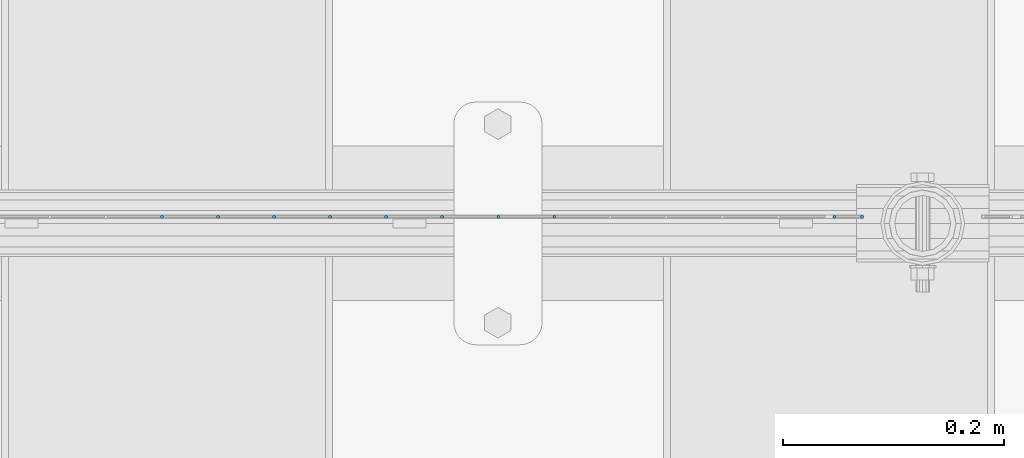
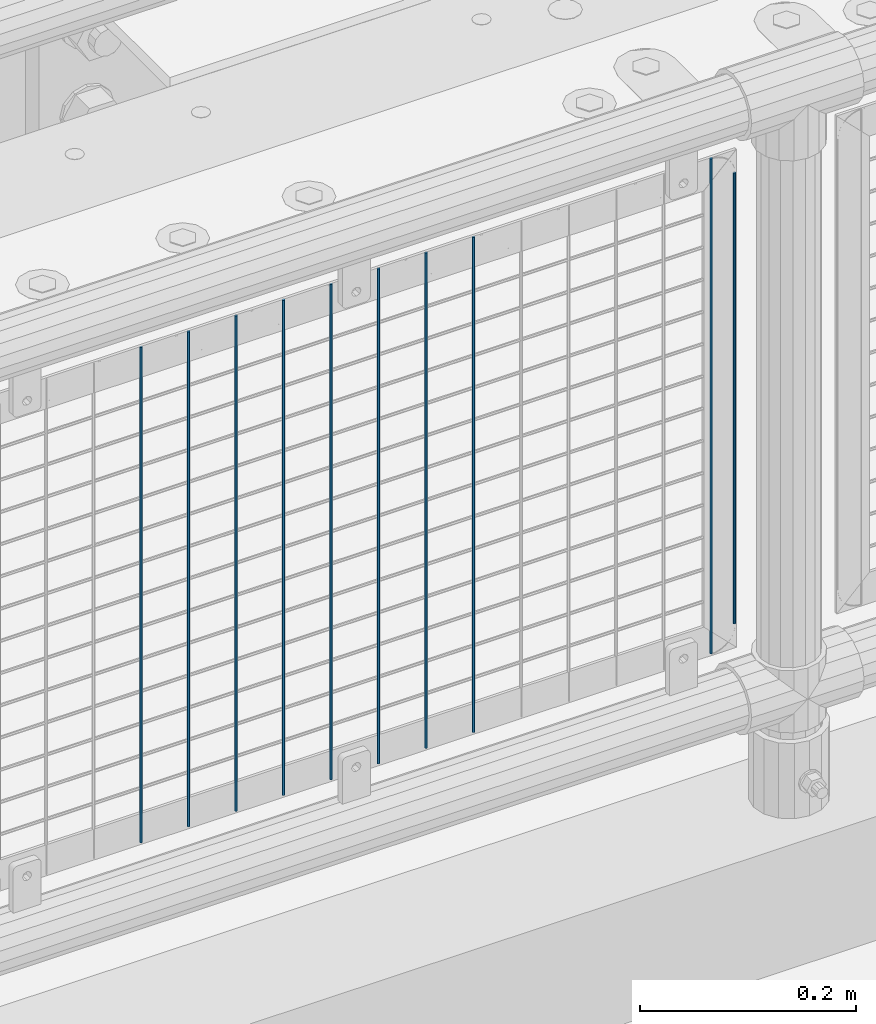
# One storey, part 92 of 242: 10 columns.
"""IFC2X3 building model written with IfcOpenShell, lengths in millimetres."""

from ifc_helpers import new_model, si_unit, frame, origin_with_axes, place, context, subcontext, project, spatial, faceted_brep, material, type_object, element, save


model = new_model("IFC2X3")

# Units and contexts
model_context = context("Model", 3, precision=1e-05, world=origin_with_axes())
body_context = subcontext(model_context, "Body", "Model", "MODEL_VIEW")
ifc_project = project(units=[si_unit("LENGTHUNIT", "METRE", prefix="MILLI"), si_unit("AREAUNIT", "SQUARE_METRE"), si_unit("VOLUMEUNIT", "CUBIC_METRE"), si_unit("MASSUNIT", "GRAM", prefix="KILO"), si_unit("TIMEUNIT", "SECOND"), si_unit("PLANEANGLEUNIT", "RADIAN"), si_unit("SOLIDANGLEUNIT", "STERADIAN"), si_unit("THERMODYNAMICTEMPERATUREUNIT", "DEGREE_CELSIUS"), si_unit("LUMINOUSINTENSITYUNIT", "LUMEN")], contexts=[model_context])

# Site, building, storey
site_placement = place(None, origin_with_axes())
site = spatial("IfcSite", under=ifc_project, at=site_placement, CompositionType="ELEMENT")
building_placement = place(site_placement, origin_with_axes())
building = spatial("IfcBuilding", under=site, at=building_placement, Name="Standard", CompositionType="ELEMENT")
storey_placement = place(building_placement, origin_with_axes())
storey = spatial("IfcBuildingStorey", under=building, at=storey_placement, Name="Undefined", CompositionType="ELEMENT", Elevation=0.0)

# Columns
ifc_material = material(Name="Misc_Undefined")
column_type = type_object("IfcColumnType", Name="D3", PredefinedType="NOTDEFINED")
for number, where, z_axis, x_axis in (
    (1, (-29098.968, -19329.5, 353.02), (-1.0, 0.0, 0.0), (0.0, 0.0, 1.0)),
    (2, (-29149.761, -19329.5, 353.02), (-1.0, 0.0, 0.0), (0.0, 0.0, 1.0)),
    (3, (-29200.554, -19329.5, 353.02), (-1.0, 0.0, 0.0), (0.0, 0.0, 1.0)),
    (4, (-28845.003, -19329.5, 353.02), (-1.0, 0.0, 0.0), (0.0, 0.0, 1.0)),
    (5, (-29251.347, -19329.5, 353.02), (-1.0, 0.0, 0.0), (0.0, 0.0, 1.0)),
    (6, (-29302.14, -19329.5, 353.02), (-1.0, 0.0, 0.0), (0.0, 0.0, 1.0)),
    (7, (-29352.933, -19329.5, 353.02), (-1.0, 0.0, 0.0), (0.0, 0.0, 1.0)),
    (8, (-29403.726, -19329.5, 353.02), (-1.0, 0.0, 0.0), (0.0, 0.0, 1.0)),
    (9, (-29454.519, -19329.5, 353.02), (-1.0, 0.0, 0.0), (0.0, 0.0, 1.0)),
):
    element("IfcColumn", number, at=place(storey_placement, frame(where, z_axis=z_axis, x_axis=x_axis)), inside=storey, type_object=column_type, material=ifc_material, ObjectType="D3", context=body_context, shape_type="Brep", body=[
        faceted_brep([(0.0, -1.50000000000364, 0.0), (-3.63797880709171e-12, -0.750000000003638, -1.29903810567669), (560.0, -0.75, -1.29903810567703), (560.0, -1.5, 0.0), (0.0, 0.749999999996362, -1.29903810567669), (560.0, 0.75, -1.29903810567703), (-3.63797880709171e-12, 1.49999999999636, 0.0), (560.0, 1.5, 0.0), (0.0, 0.749999999996362, 1.29903810567669), (560.0, 0.75, 1.29903810567703), (-3.63797880709171e-12, -0.750000000003638, 1.29903810567669), (560.0, -0.75, 1.29903810567703)], [[[0, 1, 2, 3]], [[1, 4, 5, 2]], [[4, 6, 7, 5]], [[6, 8, 9, 7]], [[8, 10, 11, 9]], [[10, 0, 3, 11]], [[5, 7, 9, 11, 3, 2]], [[10, 8, 6, 4, 1, 0]]]),
    ])
column_placement = place(storey_placement, frame((-28820.0, -19329.5, 378.02), z_axis=(-1.0, 0.0, 0.0), x_axis=(0.0, 0.0, 1.0)))
element("IfcColumn", 10, at=column_placement, inside=storey, type_object=column_type, material=ifc_material, ObjectType="D3", context=body_context, shape_type="Brep", body=[
    faceted_brep([(0.0, -1.50000000000364, 0.0), (-3.63797880709171e-12, -0.750000000003638, -1.29903810567669), (510.0, -0.75, -1.29903810567703), (510.0, -1.5, 0.0), (0.0, 0.749999999996362, -1.29903810567669), (510.0, 0.75, -1.29903810567703), (-3.63797880709171e-12, 1.49999999999636, 0.0), (510.0, 1.5, 0.0), (0.0, 0.749999999996362, 1.29903810567669), (510.0, 0.75, 1.29903810567703), (-3.63797880709171e-12, -0.750000000003638, 1.29903810567669), (510.0, -0.75, 1.29903810567703)], [[[0, 1, 2, 3]], [[1, 4, 5, 2]], [[4, 6, 7, 5]], [[6, 8, 9, 7]], [[8, 10, 11, 9]], [[10, 0, 3, 11]], [[5, 7, 9, 11, 3, 2]], [[10, 8, 6, 4, 1, 0]]]),
])

save(model, "model.ifc")
